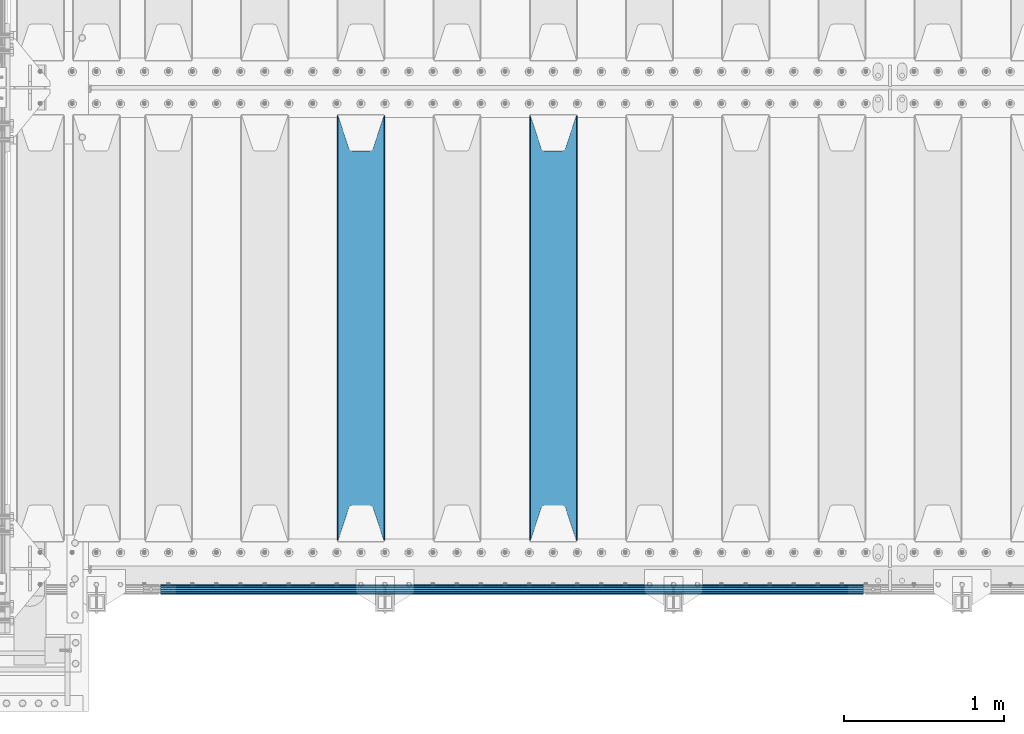
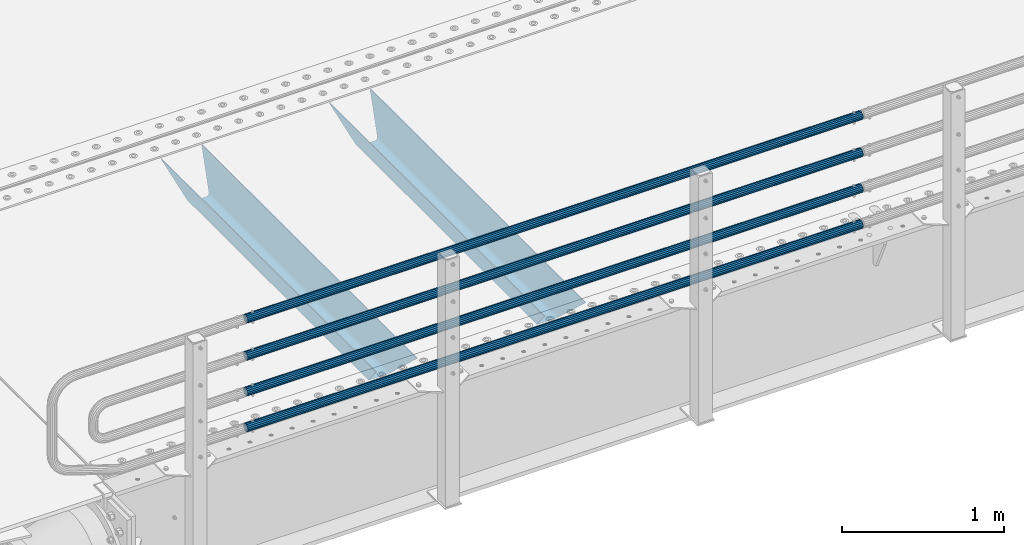
# One storey, part 102 of 257: 6 beams.
"""IFC2X3 building model written with IfcOpenShell, lengths in millimetres."""

from ifc_helpers import new_model, si_unit, frame, origin_with_axes, place, context, subcontext, project, spatial, faceted_brep, material, type_object, element, save


model = new_model("IFC2X3")

# Units and contexts
model_context = context("Model", 3, precision=1e-05, world=origin_with_axes())
body_context = subcontext(model_context, "Body", "Model", "MODEL_VIEW")
ifc_project = project(units=[si_unit("LENGTHUNIT", "METRE", prefix="MILLI"), si_unit("AREAUNIT", "SQUARE_METRE"), si_unit("VOLUMEUNIT", "CUBIC_METRE"), si_unit("MASSUNIT", "GRAM", prefix="KILO"), si_unit("TIMEUNIT", "SECOND"), si_unit("PLANEANGLEUNIT", "RADIAN"), si_unit("SOLIDANGLEUNIT", "STERADIAN"), si_unit("THERMODYNAMICTEMPERATUREUNIT", "DEGREE_CELSIUS"), si_unit("LUMINOUSINTENSITYUNIT", "LUMEN")], contexts=[model_context])

# Site, building, storey
site_placement = place(None, origin_with_axes())
site = spatial("IfcSite", under=ifc_project, at=site_placement, CompositionType="ELEMENT")
building_placement = place(site_placement, origin_with_axes())
building = spatial("IfcBuilding", under=site, at=building_placement, Name="Standard", CompositionType="ELEMENT")
storey_placement = place(building_placement, origin_with_axes())
storey = spatial("IfcBuildingStorey", under=building, at=storey_placement, Name="Undefined", CompositionType="ELEMENT", Elevation=0.0)

# Beams
ifc_material_1 = material(Name="STEEL/S355N")
beam_type_1 = type_object("IfcBeamType", PredefinedType="NOTDEFINED")
beam_1_placement = place(storey_placement, frame((45850.0, 175.0, -115.0), z_axis=(0.0, 0.0, 1.0), x_axis=(0.0, 1.0, 0.0)))
element("IfcBeam", 1, at=beam_1_placement, inside=storey, type_object=beam_type_1, material=ifc_material_1, context=body_context, shape_type="Brep", body=[
    faceted_brep([(0.0, 150.0, 115.0), (0.0, 143.690000000002, 115.0), (2650.00000000297, 143.690000000002, 115.0), (2650.00000000297, 150.0, 115.0), (2650.00000000297, 142.059565218406, 110.0000000031), (2650.00000000297, 148.369565218403, 110.0000000031), (2441.90079219208, -80.1103600731149, -98.0992078077845), (2437.7588105432, -77.5672621345584, -102.241189456673), (2434.06523489746, -74.4080125315522, -105.934765102404), (2430.91086095089, -70.7102721255724, -109.089139048974), (2428.37322971128, -66.5649389910031, -111.626770288588), (2426.51472138055, -62.0739139532889, -113.485278619323), (2425.38102192091, -57.3475956567636, -114.618978078955), (2424.99999999987, -52.5021667386536, -115.0), (2424.99999999987, 52.5021667386536, -115.0), (2425.38102192091, 57.3475956567636, -114.618978078955), (2426.51472138055, 62.0739139532889, -113.485278619323), (2428.37322971128, 66.5649389910031, -111.626770288588), (2430.91086095089, 70.7102721255724, -109.089139048974), (2434.06523489746, 74.4080125315522, -105.934765102404), (2437.7588105432, 77.5672621345584, -102.241189456673), (2441.90079219208, 80.1103600731149, -98.0992078077846), (2446.38936140511, 81.9747917625791, -93.6106385947584), (2448.24948500409, 76.2713538057287, -91.7505149957729), (2444.62967112262, 74.76777986261, -95.3703288772456), (2441.28936334126, 72.7168944282894, -98.710636658607), (2438.31067330438, 70.1691124903809, -101.689326695487), (2435.76682334747, 67.1870637758839, -104.233176652398), (2433.72034654133, 63.8440531834931, -106.279653458539), (2432.22154950041, 60.2222587982324, -107.778450499454), (2431.30727574265, 56.4107117849126, -108.692724257221), (2430.99999999987, 52.5031078186876, -109.0), (2430.99999999987, -52.5031078186876, -109.0), (2431.30727574265, -56.4107117849126, -108.692724257221), (2432.22154950041, -60.2222587982324, -107.778450499454), (2433.72034654133, -63.8440531834931, -106.279653458539), (2435.76682334747, -67.1870637758839, -104.233176652398), (2438.31067330438, -70.1691124903809, -101.689326695487), (2441.28936334126, -72.7168944282894, -98.7106366586071), (2444.62967112262, -74.76777986261, -95.3703288772457), (2448.24948500409, -76.2713538057287, -91.7505149957729), (2650.00000000297, -142.059565218406, 110.0000000031), (2650.00000000297, -148.369565218403, 110.0000000031), (2446.38936140511, -81.9747917625791, -93.6106385947584), (2650.00000000297, -143.690000000002, 115.0), (2650.00000000297, -150.0, 115.0), (0.0, -143.690000000002, 115.0), (0.0, -150.0, 115.0), (0.0, -148.369565218258, 110.000000002662), (203.61063859742, -81.9747917625791, -93.6106385947584), (208.099207810447, -80.1103600731149, -98.0992078077845), (212.241189459335, -77.5672621345584, -102.241189456673), (215.934765105066, -74.4080125315522, -105.934765102404), (219.089139051636, -70.7102721255724, -109.089139048974), (221.626770291251, -66.5649389910031, -111.626770288588), (223.485278621985, -62.0739139532889, -113.485278619323), (224.618978081617, -57.3475956567636, -114.618978078955), (225.000000002662, -52.5021667386536, -115.0), (225.000000002662, 52.5021667386536, -115.0), (224.618978081617, 57.3475956567636, -114.618978078955), (223.485278621985, 62.0739139532889, -113.485278619323), (221.626770291251, 66.5649389910031, -111.626770288588), (219.089139051636, 70.7102721255724, -109.089139048974), (215.934765105066, 74.4080125315522, -105.934765102404), (212.241189459335, 77.5672621345584, -102.241189456673), (208.099207810447, 80.1103600731149, -98.0992078077846), (203.61063859742, 81.9747917625791, -93.6106385947584), (0.0, 148.369565218258, 110.000000002662), (0.0, 142.05956521826, 110.000000002662), (201.750514998435, 76.2713538057287, -91.7505149957729), (205.370328879908, 74.76777986261, -95.3703288772456), (208.710636661269, 72.7168944282894, -98.710636658607), (211.689326698149, 70.1691124903809, -101.689326695487), (214.233176655061, 67.1870637758839, -104.233176652398), (216.279653461201, 63.8440531834931, -106.279653458539), (217.778450502116, 60.2222587982324, -107.778450499454), (218.692724259884, 56.4107117849126, -108.692724257221), (219.000000002662, 52.5031078186876, -109.0), (219.000000002662, -52.5031078186876, -109.0), (218.692724259884, -56.4107117849126, -108.692724257221), (217.778450502116, -60.2222587982324, -107.778450499454), (216.279653461201, -63.8440531834931, -106.279653458539), (214.233176655061, -67.1870637758839, -104.233176652398), (211.689326698149, -70.1691124903809, -101.689326695487), (208.710636661269, -72.7168944282894, -98.7106366586071), (205.370328879908, -74.76777986261, -95.3703288772457), (201.750514998435, -76.2713538057287, -91.7505149957729), (0.0, -142.05956521826, 110.000000002662)], [[[0, 1, 2, 3]], [[3, 2, 4, 5]], [[6, 7, 8, 9, 10, 11, 12, 13, 14, 15, 16, 17, 18, 19, 20, 21, 22, 5, 4, 23, 24, 25, 26, 27, 28, 29, 30, 31, 32, 33, 34, 35, 36, 37, 38, 39, 40, 41, 42, 43]], [[44, 45, 42, 41]], [[46, 47, 45, 44]], [[43, 42, 45, 47, 48, 49]], [[6, 43, 49, 50]], [[7, 6, 50, 51]], [[8, 7, 51, 52]], [[9, 8, 52, 53]], [[10, 9, 53, 54]], [[11, 10, 54, 55]], [[12, 11, 55, 56]], [[13, 12, 56, 57]], [[14, 13, 57, 58]], [[15, 14, 58, 59]], [[16, 15, 59, 60]], [[17, 16, 60, 61]], [[18, 17, 61, 62]], [[19, 18, 62, 63]], [[20, 19, 63, 64]], [[21, 20, 64, 65]], [[22, 21, 65, 66]], [[0, 3, 5, 22, 66, 67]], [[1, 0, 67, 68]], [[23, 4, 2, 1, 68, 69]], [[24, 23, 69, 70]], [[25, 24, 70, 71]], [[26, 25, 71, 72]], [[27, 26, 72, 73]], [[28, 27, 73, 74]], [[29, 28, 74, 75]], [[30, 29, 75, 76]], [[31, 30, 76, 77]], [[32, 31, 77, 78]], [[33, 32, 78, 79]], [[34, 33, 79, 80]], [[35, 34, 80, 81]], [[36, 35, 81, 82]], [[37, 36, 82, 83]], [[38, 37, 83, 84]], [[39, 38, 84, 85]], [[40, 39, 85, 86]], [[46, 44, 41, 40, 86, 87]], [[47, 46, 87, 48]], [[86, 85, 84, 83, 82, 81, 80, 79, 78, 77, 76, 75, 74, 73, 72, 71, 70, 69, 68, 67, 66, 65, 64, 63, 62, 61, 60, 59, 58, 57, 56, 55, 54, 53, 52, 51, 50, 49, 48, 87]]]),
])
beam_2_placement = place(storey_placement, frame((44650.0, 175.0, -115.0), z_axis=(0.0, 0.0, 1.0), x_axis=(0.0, 1.0, 0.0)))
element("IfcBeam", 2, at=beam_2_placement, inside=storey, type_object=beam_type_1, material=ifc_material_1, context=body_context, shape_type="Brep", body=[
    faceted_brep([(0.0, 150.0, 115.0), (0.0, 143.690000000002, 115.0), (2650.00000000297, 143.690000000002, 115.0), (2650.00000000297, 150.0, 115.0), (2650.00000000297, 142.059565218406, 110.0000000031), (2650.00000000297, 148.369565218403, 110.0000000031), (2441.90079219208, -80.1103600731149, -98.0992078077845), (2437.7588105432, -77.5672621345584, -102.241189456673), (2434.06523489746, -74.4080125315522, -105.934765102404), (2430.91086095089, -70.7102721255724, -109.089139048974), (2428.37322971128, -66.5649389910031, -111.626770288588), (2426.51472138055, -62.0739139532889, -113.485278619323), (2425.38102192091, -57.3475956567636, -114.618978078955), (2424.99999999987, -52.5021667386536, -115.0), (2424.99999999987, 52.5021667386536, -115.0), (2425.38102192091, 57.3475956567636, -114.618978078955), (2426.51472138055, 62.0739139532889, -113.485278619323), (2428.37322971128, 66.5649389910031, -111.626770288588), (2430.91086095089, 70.7102721255724, -109.089139048974), (2434.06523489746, 74.4080125315522, -105.934765102404), (2437.7588105432, 77.5672621345584, -102.241189456673), (2441.90079219208, 80.1103600731149, -98.0992078077846), (2446.38936140511, 81.9747917625791, -93.6106385947584), (2448.24948500409, 76.2713538057287, -91.7505149957729), (2444.62967112262, 74.76777986261, -95.3703288772456), (2441.28936334126, 72.7168944282894, -98.710636658607), (2438.31067330438, 70.1691124903809, -101.689326695487), (2435.76682334747, 67.1870637758839, -104.233176652398), (2433.72034654133, 63.8440531834931, -106.279653458539), (2432.22154950041, 60.2222587982324, -107.778450499454), (2431.30727574265, 56.4107117849126, -108.692724257221), (2430.99999999987, 52.5031078186876, -109.0), (2430.99999999987, -52.5031078186876, -109.0), (2431.30727574265, -56.4107117849126, -108.692724257221), (2432.22154950041, -60.2222587982324, -107.778450499454), (2433.72034654133, -63.8440531834931, -106.279653458539), (2435.76682334747, -67.1870637758839, -104.233176652398), (2438.31067330438, -70.1691124903809, -101.689326695487), (2441.28936334126, -72.7168944282894, -98.7106366586071), (2444.62967112262, -74.76777986261, -95.3703288772457), (2448.24948500409, -76.2713538057287, -91.7505149957729), (2650.00000000297, -142.059565218406, 110.0000000031), (2650.00000000297, -148.369565218403, 110.0000000031), (2446.38936140511, -81.9747917625791, -93.6106385947584), (2650.00000000297, -143.690000000002, 115.0), (2650.00000000297, -150.0, 115.0), (0.0, -143.690000000002, 115.0), (0.0, -150.0, 115.0), (0.0, -148.369565218258, 110.000000002662), (203.61063859742, -81.9747917625791, -93.6106385947584), (208.099207810447, -80.1103600731149, -98.0992078077845), (212.241189459335, -77.5672621345584, -102.241189456673), (215.934765105066, -74.4080125315522, -105.934765102404), (219.089139051636, -70.7102721255724, -109.089139048974), (221.626770291251, -66.5649389910031, -111.626770288588), (223.485278621985, -62.0739139532889, -113.485278619323), (224.618978081617, -57.3475956567636, -114.618978078955), (225.000000002662, -52.5021667386536, -115.0), (225.000000002662, 52.5021667386536, -115.0), (224.618978081617, 57.3475956567636, -114.618978078955), (223.485278621985, 62.0739139532889, -113.485278619323), (221.626770291251, 66.5649389910031, -111.626770288588), (219.089139051636, 70.7102721255724, -109.089139048974), (215.934765105066, 74.4080125315522, -105.934765102404), (212.241189459335, 77.5672621345584, -102.241189456673), (208.099207810447, 80.1103600731149, -98.0992078077846), (203.61063859742, 81.9747917625791, -93.6106385947584), (0.0, 148.369565218258, 110.000000002662), (0.0, 142.05956521826, 110.000000002662), (201.750514998435, 76.2713538057287, -91.7505149957729), (205.370328879908, 74.76777986261, -95.3703288772456), (208.710636661269, 72.7168944282894, -98.710636658607), (211.689326698149, 70.1691124903809, -101.689326695487), (214.233176655061, 67.1870637758839, -104.233176652398), (216.279653461201, 63.8440531834931, -106.279653458539), (217.778450502116, 60.2222587982324, -107.778450499454), (218.692724259884, 56.4107117849126, -108.692724257221), (219.000000002662, 52.5031078186876, -109.0), (219.000000002662, -52.5031078186876, -109.0), (218.692724259884, -56.4107117849126, -108.692724257221), (217.778450502116, -60.2222587982324, -107.778450499454), (216.279653461201, -63.8440531834931, -106.279653458539), (214.233176655061, -67.1870637758839, -104.233176652398), (211.689326698149, -70.1691124903809, -101.689326695487), (208.710636661269, -72.7168944282894, -98.7106366586071), (205.370328879908, -74.76777986261, -95.3703288772457), (201.750514998435, -76.2713538057287, -91.7505149957729), (0.0, -142.05956521826, 110.000000002662)], [[[0, 1, 2, 3]], [[3, 2, 4, 5]], [[6, 7, 8, 9, 10, 11, 12, 13, 14, 15, 16, 17, 18, 19, 20, 21, 22, 5, 4, 23, 24, 25, 26, 27, 28, 29, 30, 31, 32, 33, 34, 35, 36, 37, 38, 39, 40, 41, 42, 43]], [[44, 45, 42, 41]], [[46, 47, 45, 44]], [[43, 42, 45, 47, 48, 49]], [[6, 43, 49, 50]], [[7, 6, 50, 51]], [[8, 7, 51, 52]], [[9, 8, 52, 53]], [[10, 9, 53, 54]], [[11, 10, 54, 55]], [[12, 11, 55, 56]], [[13, 12, 56, 57]], [[14, 13, 57, 58]], [[15, 14, 58, 59]], [[16, 15, 59, 60]], [[17, 16, 60, 61]], [[18, 17, 61, 62]], [[19, 18, 62, 63]], [[20, 19, 63, 64]], [[21, 20, 64, 65]], [[22, 21, 65, 66]], [[0, 3, 5, 22, 66, 67]], [[1, 0, 67, 68]], [[23, 4, 2, 1, 68, 69]], [[24, 23, 69, 70]], [[25, 24, 70, 71]], [[26, 25, 71, 72]], [[27, 26, 72, 73]], [[28, 27, 73, 74]], [[29, 28, 74, 75]], [[30, 29, 75, 76]], [[31, 30, 76, 77]], [[32, 31, 77, 78]], [[33, 32, 78, 79]], [[34, 33, 79, 80]], [[35, 34, 80, 81]], [[36, 35, 81, 82]], [[37, 36, 82, 83]], [[38, 37, 83, 84]], [[39, 38, 84, 85]], [[40, 39, 85, 86]], [[46, 44, 41, 40, 86, 87]], [[47, 46, 87, 48]], [[86, 85, 84, 83, 82, 81, 80, 79, 78, 77, 76, 75, 74, 73, 72, 71, 70, 69, 68, 67, 66, 65, 64, 63, 62, 61, 60, 59, 58, 57, 56, 55, 54, 53, 52, 51, 50, 49, 48, 87]]]),
])
ifc_material_2 = material()
beam_type_2 = type_object("IfcBeamType", PredefinedType="NOTDEFINED")
beam_3_placement = place(storey_placement, frame((47783.9999999999, -129.849999999907, 149.849999999725), z_axis=(0.0, 0.0, -1.0), x_axis=(-1.0, 0.0, 0.0)))
element("IfcBeam", 3, at=beam_3_placement, inside=storey, type_object=beam_type_2, material=ifc_material_2, context=body_context, shape_type="Brep", body=[
    faceted_brep([(0.0, -26.5499999999993, 0.0), (0.0, -24.5290015881747, 10.1602451292931), (4384.00249699992, -24.5290015881747, 10.1602451292931), (4384.00249699992, -26.5499999999993, 0.0), (0.0, -18.7736850405036, 18.7736850405028), (4384.00249699992, -18.7736850405036, 18.7736850405028), (0.0, -10.1602451292929, 24.5290015881747), (4384.00249699992, -10.1602451292929, 24.5290015881747), (0.0, 0.0, 26.55), (4384.00249699992, 0.0, 26.55), (0.0, 10.1602451292929, 24.5290015881747), (4384.00249699992, 10.1602451292929, 24.5290015881747), (0.0, 18.7736850405036, 18.7736850405028), (4384.00249699992, 18.7736850405036, 18.7736850405028), (0.0, 24.5290015881747, 10.1602451292931), (4384.00249699992, 24.5290015881747, 10.1602451292931), (0.0, 26.5499999999993, 0.0), (4384.00249699992, 26.5499999999993, 0.0), (0.0, 24.5290015881747, -10.1602451292931), (4384.00249699992, 24.5290015881747, -10.1602451292931), (0.0, 18.7736850405036, -18.7736850405028), (4384.00249699992, 18.7736850405036, -18.7736850405028), (0.0, 10.1602451292929, -24.5290015881747), (4384.00249699992, 10.1602451292929, -24.5290015881747), (0.0, 0.0, -26.55), (4384.00249699992, 0.0, -26.55), (0.0, -10.1602451292929, -24.5290015881747), (4384.00249699992, -10.1602451292929, -24.5290015881747), (0.0, -18.7736850405036, -18.7736850405028), (4384.00249699992, -18.7736850405036, -18.7736850405028), (0.0, -24.5290015881747, -10.1602451292931), (4384.00249699992, -24.5290015881747, -10.1602451292931), (0.0, -30.1499999999996, 0.0), (0.0, -27.8549679052157, -11.5379054858058), (4384.00249699992, -27.8549679052157, -11.5379054858075), (4384.00249699992, -30.1499999999996, 0.0), (0.0, -21.3192694527752, -21.3192694527752), (4384.00249699992, -21.3192694527752, -21.3192694527744), (0.0, -11.5379054858076, -27.8549679052157), (4384.00249699992, -11.5379054858076, -27.8549679052153), (0.0, 0.0, -30.1500000000015), (4384.00249699992, 0.0, -30.15), (0.0, 11.5379054858076, -27.8549679052157), (4384.00249699992, 11.5379054858076, -27.8549679052153), (0.0, 21.3192694527752, -21.3192694527752), (4384.00249699992, 21.3192694527752, -21.3192694527744), (0.0, 27.8549679052157, -11.5379054858058), (4384.00249699992, 27.8549679052157, -11.5379054858074), (0.0, 30.1499999999996, 0.0), (4384.00249699992, 30.1499999999996, 0.0), (0.0, 27.8549679052157, 11.5379054858058), (4384.00249699992, 27.8549679052157, 11.5379054858075), (0.0, 21.3192694527752, 21.3192694527752), (4384.00249699992, 21.3192694527752, 21.3192694527744), (0.0, 11.5379054858076, 27.8549679052157), (4384.00249699992, 11.5379054858076, 27.8549679052153), (0.0, 0.0, 30.1500000000015), (4384.00249699992, 0.0, 30.15), (0.0, -11.5379054858076, 27.8549679052157), (4384.00249699992, -11.5379054858076, 27.8549679052153), (0.0, -21.3192694527752, 21.3192694527752), (4384.00249699992, -21.3192694527752, 21.3192694527744), (0.0, -27.8549679052157, 11.5379054858058), (4384.00249699992, -27.8549679052157, 11.5379054858075)], [[[0, 1, 2, 3]], [[1, 4, 5, 2]], [[4, 6, 7, 5]], [[6, 8, 9, 7]], [[8, 10, 11, 9]], [[10, 12, 13, 11]], [[12, 14, 15, 13]], [[14, 16, 17, 15]], [[16, 18, 19, 17]], [[18, 20, 21, 19]], [[20, 22, 23, 21]], [[22, 24, 25, 23]], [[24, 26, 27, 25]], [[26, 28, 29, 27]], [[28, 30, 31, 29]], [[30, 0, 3, 31]], [[32, 33, 34, 35]], [[33, 36, 37, 34]], [[36, 38, 39, 37]], [[38, 40, 41, 39]], [[40, 42, 43, 41]], [[42, 44, 45, 43]], [[44, 46, 47, 45]], [[46, 48, 49, 47]], [[48, 50, 51, 49]], [[50, 52, 53, 51]], [[52, 54, 55, 53]], [[54, 56, 57, 55]], [[56, 58, 59, 57]], [[58, 60, 61, 59]], [[60, 62, 63, 61]], [[62, 32, 35, 63]], [[37, 39, 41, 43, 45, 47, 49, 51, 53, 55, 57, 59, 61, 63, 35, 34], [5, 7, 9, 11, 13, 15, 17, 19, 21, 23, 25, 27, 29, 31, 3, 2]], [[62, 60, 58, 56, 54, 52, 50, 48, 46, 44, 42, 40, 38, 36, 33, 32], [30, 28, 26, 24, 22, 20, 18, 16, 14, 12, 10, 8, 6, 4, 1, 0]]]),
])
beam_4_placement = place(storey_placement, frame((47783.9999999999, -129.849999999907, 420.149999999728), z_axis=(0.0, 0.0, -1.0), x_axis=(-1.0, 0.0, 0.0)))
element("IfcBeam", 4, at=beam_4_placement, inside=storey, type_object=beam_type_2, material=ifc_material_2, context=body_context, shape_type="Brep", body=[
    faceted_brep([(0.0, -26.5499999999993, 0.0), (0.0, -24.5290015881747, 10.1602451292931), (4384.00249699992, -24.5290015881747, 10.1602451292931), (4384.00249699992, -26.5499999999993, 0.0), (0.0, -18.7736850405036, 18.7736850405028), (4384.00249699992, -18.7736850405036, 18.7736850405028), (0.0, -10.1602451292929, 24.5290015881747), (4384.00249699992, -10.1602451292929, 24.5290015881747), (0.0, 0.0, 26.55), (4384.00249699992, 0.0, 26.55), (0.0, 10.1602451292929, 24.5290015881747), (4384.00249699992, 10.1602451292929, 24.5290015881747), (0.0, 18.7736850405036, 18.7736850405028), (4384.00249699992, 18.7736850405036, 18.7736850405028), (0.0, 24.5290015881747, 10.1602451292931), (4384.00249699992, 24.5290015881747, 10.1602451292931), (0.0, 26.5499999999993, 0.0), (4384.00249699992, 26.5499999999993, 0.0), (0.0, 24.5290015881747, -10.1602451292931), (4384.00249699992, 24.5290015881747, -10.1602451292931), (0.0, 18.7736850405036, -18.7736850405028), (4384.00249699992, 18.7736850405036, -18.7736850405028), (0.0, 10.1602451292929, -24.5290015881747), (4384.00249699992, 10.1602451292929, -24.5290015881747), (0.0, 0.0, -26.55), (4384.00249699992, 0.0, -26.55), (0.0, -10.1602451292929, -24.5290015881747), (4384.00249699992, -10.1602451292929, -24.5290015881747), (0.0, -18.7736850405036, -18.7736850405028), (4384.00249699992, -18.7736850405036, -18.7736850405028), (0.0, -24.5290015881747, -10.1602451292931), (4384.00249699992, -24.5290015881747, -10.1602451292931), (0.0, -30.1499999999996, 0.0), (0.0, -27.8549679052157, -11.5379054858058), (4384.00249699992, -27.8549679052157, -11.5379054858075), (4384.00249699992, -30.1499999999996, 0.0), (0.0, -21.3192694527752, -21.3192694527752), (4384.00249699992, -21.3192694527752, -21.3192694527744), (0.0, -11.5379054858076, -27.8549679052157), (4384.00249699992, -11.5379054858076, -27.8549679052153), (0.0, 0.0, -30.1500000000015), (4384.00249699992, 0.0, -30.15), (0.0, 11.5379054858076, -27.8549679052157), (4384.00249699992, 11.5379054858076, -27.8549679052153), (0.0, 21.3192694527752, -21.3192694527752), (4384.00249699992, 21.3192694527752, -21.3192694527744), (0.0, 27.8549679052157, -11.5379054858058), (4384.00249699992, 27.8549679052157, -11.5379054858074), (0.0, 30.1499999999996, 0.0), (4384.00249699992, 30.1499999999996, 0.0), (0.0, 27.8549679052157, 11.5379054858058), (4384.00249699992, 27.8549679052157, 11.5379054858075), (0.0, 21.3192694527752, 21.3192694527752), (4384.00249699992, 21.3192694527752, 21.3192694527744), (0.0, 11.5379054858076, 27.8549679052157), (4384.00249699992, 11.5379054858076, 27.8549679052153), (0.0, 0.0, 30.1500000000015), (4384.00249699992, 0.0, 30.15), (0.0, -11.5379054858076, 27.8549679052157), (4384.00249699992, -11.5379054858076, 27.8549679052153), (0.0, -21.3192694527752, 21.3192694527752), (4384.00249699992, -21.3192694527752, 21.3192694527744), (0.0, -27.8549679052157, 11.5379054858058), (4384.00249699992, -27.8549679052157, 11.5379054858075)], [[[0, 1, 2, 3]], [[1, 4, 5, 2]], [[4, 6, 7, 5]], [[6, 8, 9, 7]], [[8, 10, 11, 9]], [[10, 12, 13, 11]], [[12, 14, 15, 13]], [[14, 16, 17, 15]], [[16, 18, 19, 17]], [[18, 20, 21, 19]], [[20, 22, 23, 21]], [[22, 24, 25, 23]], [[24, 26, 27, 25]], [[26, 28, 29, 27]], [[28, 30, 31, 29]], [[30, 0, 3, 31]], [[32, 33, 34, 35]], [[33, 36, 37, 34]], [[36, 38, 39, 37]], [[38, 40, 41, 39]], [[40, 42, 43, 41]], [[42, 44, 45, 43]], [[44, 46, 47, 45]], [[46, 48, 49, 47]], [[48, 50, 51, 49]], [[50, 52, 53, 51]], [[52, 54, 55, 53]], [[54, 56, 57, 55]], [[56, 58, 59, 57]], [[58, 60, 61, 59]], [[60, 62, 63, 61]], [[62, 32, 35, 63]], [[37, 39, 41, 43, 45, 47, 49, 51, 53, 55, 57, 59, 61, 63, 35, 34], [5, 7, 9, 11, 13, 15, 17, 19, 21, 23, 25, 27, 29, 31, 3, 2]], [[62, 60, 58, 56, 54, 52, 50, 48, 46, 44, 42, 40, 38, 36, 33, 32], [30, 28, 26, 24, 22, 20, 18, 16, 14, 12, 10, 8, 6, 4, 1, 0]]]),
])
beam_5_placement = place(storey_placement, frame((47783.9999999999, -129.849999999907, 969.849999999725), z_axis=(0.0, 0.0, -1.0), x_axis=(-1.0, 0.0, 0.0)))
element("IfcBeam", 5, at=beam_5_placement, inside=storey, type_object=beam_type_2, material=ifc_material_2, context=body_context, shape_type="Brep", body=[
    faceted_brep([(0.0, -26.5499999999993, 0.0), (0.0, -24.5290015881747, 10.1602451292931), (4384.00249699992, -24.5290015881747, 10.1602451292931), (4384.00249699992, -26.5499999999993, 0.0), (0.0, -18.7736850405036, 18.7736850405028), (4384.00249699992, -18.7736850405036, 18.7736850405028), (0.0, -10.1602451292929, 24.5290015881747), (4384.00249699992, -10.1602451292929, 24.5290015881747), (0.0, 0.0, 26.55), (4384.00249699992, 0.0, 26.55), (0.0, 10.1602451292929, 24.5290015881747), (4384.00249699992, 10.1602451292929, 24.5290015881747), (0.0, 18.7736850405036, 18.7736850405028), (4384.00249699992, 18.7736850405036, 18.7736850405028), (0.0, 24.5290015881747, 10.1602451292931), (4384.00249699992, 24.5290015881747, 10.1602451292931), (0.0, 26.5499999999993, 0.0), (4384.00249699992, 26.5499999999993, 0.0), (0.0, 24.5290015881747, -10.1602451292931), (4384.00249699992, 24.5290015881747, -10.1602451292931), (0.0, 18.7736850405036, -18.7736850405028), (4384.00249699992, 18.7736850405036, -18.7736850405028), (0.0, 10.1602451292929, -24.5290015881747), (4384.00249699992, 10.1602451292929, -24.5290015881747), (0.0, 0.0, -26.55), (4384.00249699992, 0.0, -26.55), (0.0, -10.1602451292929, -24.5290015881747), (4384.00249699992, -10.1602451292929, -24.5290015881747), (0.0, -18.7736850405036, -18.7736850405028), (4384.00249699992, -18.7736850405036, -18.7736850405028), (0.0, -24.5290015881747, -10.1602451292931), (4384.00249699992, -24.5290015881747, -10.1602451292931), (0.0, -30.1499999999996, 0.0), (0.0, -27.8549679052157, -11.5379054858058), (4384.00249699992, -27.8549679052157, -11.5379054858075), (4384.00249699992, -30.1499999999996, 0.0), (0.0, -21.3192694527752, -21.3192694527752), (4384.00249699992, -21.3192694527752, -21.3192694527744), (0.0, -11.5379054858076, -27.8549679052157), (4384.00249699992, -11.5379054858076, -27.8549679052153), (0.0, 0.0, -30.1500000000015), (4384.00249699992, 0.0, -30.15), (0.0, 11.5379054858076, -27.8549679052157), (4384.00249699992, 11.5379054858076, -27.8549679052153), (0.0, 21.3192694527752, -21.3192694527752), (4384.00249699992, 21.3192694527752, -21.3192694527744), (0.0, 27.8549679052157, -11.5379054858058), (4384.00249699992, 27.8549679052157, -11.5379054858074), (0.0, 30.1499999999996, 0.0), (4384.00249699992, 30.1499999999996, 0.0), (0.0, 27.8549679052157, 11.5379054858058), (4384.00249699992, 27.8549679052157, 11.5379054858075), (0.0, 21.3192694527752, 21.3192694527752), (4384.00249699992, 21.3192694527752, 21.3192694527744), (0.0, 11.5379054858076, 27.8549679052157), (4384.00249699992, 11.5379054858076, 27.8549679052153), (0.0, 0.0, 30.1500000000015), (4384.00249699992, 0.0, 30.15), (0.0, -11.5379054858076, 27.8549679052157), (4384.00249699992, -11.5379054858076, 27.8549679052153), (0.0, -21.3192694527752, 21.3192694527752), (4384.00249699992, -21.3192694527752, 21.3192694527744), (0.0, -27.8549679052157, 11.5379054858058), (4384.00249699992, -27.8549679052157, 11.5379054858075)], [[[0, 1, 2, 3]], [[1, 4, 5, 2]], [[4, 6, 7, 5]], [[6, 8, 9, 7]], [[8, 10, 11, 9]], [[10, 12, 13, 11]], [[12, 14, 15, 13]], [[14, 16, 17, 15]], [[16, 18, 19, 17]], [[18, 20, 21, 19]], [[20, 22, 23, 21]], [[22, 24, 25, 23]], [[24, 26, 27, 25]], [[26, 28, 29, 27]], [[28, 30, 31, 29]], [[30, 0, 3, 31]], [[32, 33, 34, 35]], [[33, 36, 37, 34]], [[36, 38, 39, 37]], [[38, 40, 41, 39]], [[40, 42, 43, 41]], [[42, 44, 45, 43]], [[44, 46, 47, 45]], [[46, 48, 49, 47]], [[48, 50, 51, 49]], [[50, 52, 53, 51]], [[52, 54, 55, 53]], [[54, 56, 57, 55]], [[56, 58, 59, 57]], [[58, 60, 61, 59]], [[60, 62, 63, 61]], [[62, 32, 35, 63]], [[37, 39, 41, 43, 45, 47, 49, 51, 53, 55, 57, 59, 61, 63, 35, 34], [5, 7, 9, 11, 13, 15, 17, 19, 21, 23, 25, 27, 29, 31, 3, 2]], [[62, 60, 58, 56, 54, 52, 50, 48, 46, 44, 42, 40, 38, 36, 33, 32], [30, 28, 26, 24, 22, 20, 18, 16, 14, 12, 10, 8, 6, 4, 1, 0]]]),
])
beam_6_placement = place(storey_placement, frame((47783.9999999999, -129.849999999907, 689.849999999725), z_axis=(0.0, 0.0, -1.0), x_axis=(-1.0, 0.0, 0.0)))
element("IfcBeam", 6, at=beam_6_placement, inside=storey, type_object=beam_type_2, material=ifc_material_2, context=body_context, shape_type="Brep", body=[
    faceted_brep([(0.0, -26.5499999999993, 0.0), (0.0, -24.5290015881747, 10.1602451292931), (4384.00249699992, -24.5290015881747, 10.1602451292931), (4384.00249699992, -26.5499999999993, 0.0), (0.0, -18.7736850405036, 18.7736850405028), (4384.00249699992, -18.7736850405036, 18.7736850405028), (0.0, -10.1602451292929, 24.5290015881747), (4384.00249699992, -10.1602451292929, 24.5290015881747), (0.0, 0.0, 26.55), (4384.00249699992, 0.0, 26.55), (0.0, 10.1602451292929, 24.5290015881747), (4384.00249699992, 10.1602451292929, 24.5290015881747), (0.0, 18.7736850405036, 18.7736850405028), (4384.00249699992, 18.7736850405036, 18.7736850405028), (0.0, 24.5290015881747, 10.1602451292931), (4384.00249699992, 24.5290015881747, 10.1602451292931), (0.0, 26.5499999999993, 0.0), (4384.00249699992, 26.5499999999993, 0.0), (0.0, 24.5290015881747, -10.1602451292931), (4384.00249699992, 24.5290015881747, -10.1602451292931), (0.0, 18.7736850405036, -18.7736850405028), (4384.00249699992, 18.7736850405036, -18.7736850405028), (0.0, 10.1602451292929, -24.5290015881747), (4384.00249699992, 10.1602451292929, -24.5290015881747), (0.0, 0.0, -26.55), (4384.00249699992, 0.0, -26.55), (0.0, -10.1602451292929, -24.5290015881747), (4384.00249699992, -10.1602451292929, -24.5290015881747), (0.0, -18.7736850405036, -18.7736850405028), (4384.00249699992, -18.7736850405036, -18.7736850405028), (0.0, -24.5290015881747, -10.1602451292931), (4384.00249699992, -24.5290015881747, -10.1602451292931), (0.0, -30.1499999999996, 0.0), (0.0, -27.8549679052157, -11.5379054858058), (4384.00249699992, -27.8549679052157, -11.5379054858075), (4384.00249699992, -30.1499999999996, 0.0), (0.0, -21.3192694527752, -21.3192694527752), (4384.00249699992, -21.3192694527752, -21.3192694527744), (0.0, -11.5379054858076, -27.8549679052157), (4384.00249699992, -11.5379054858076, -27.8549679052153), (0.0, 0.0, -30.1500000000015), (4384.00249699992, 0.0, -30.15), (0.0, 11.5379054858076, -27.8549679052157), (4384.00249699992, 11.5379054858076, -27.8549679052153), (0.0, 21.3192694527752, -21.3192694527752), (4384.00249699992, 21.3192694527752, -21.3192694527744), (0.0, 27.8549679052157, -11.5379054858058), (4384.00249699992, 27.8549679052157, -11.5379054858074), (0.0, 30.1499999999996, 0.0), (4384.00249699992, 30.1499999999996, 0.0), (0.0, 27.8549679052157, 11.5379054858058), (4384.00249699992, 27.8549679052157, 11.5379054858075), (0.0, 21.3192694527752, 21.3192694527752), (4384.00249699992, 21.3192694527752, 21.3192694527744), (0.0, 11.5379054858076, 27.8549679052157), (4384.00249699992, 11.5379054858076, 27.8549679052153), (0.0, 0.0, 30.1500000000015), (4384.00249699992, 0.0, 30.15), (0.0, -11.5379054858076, 27.8549679052157), (4384.00249699992, -11.5379054858076, 27.8549679052153), (0.0, -21.3192694527752, 21.3192694527752), (4384.00249699992, -21.3192694527752, 21.3192694527744), (0.0, -27.8549679052157, 11.5379054858058), (4384.00249699992, -27.8549679052157, 11.5379054858075)], [[[0, 1, 2, 3]], [[1, 4, 5, 2]], [[4, 6, 7, 5]], [[6, 8, 9, 7]], [[8, 10, 11, 9]], [[10, 12, 13, 11]], [[12, 14, 15, 13]], [[14, 16, 17, 15]], [[16, 18, 19, 17]], [[18, 20, 21, 19]], [[20, 22, 23, 21]], [[22, 24, 25, 23]], [[24, 26, 27, 25]], [[26, 28, 29, 27]], [[28, 30, 31, 29]], [[30, 0, 3, 31]], [[32, 33, 34, 35]], [[33, 36, 37, 34]], [[36, 38, 39, 37]], [[38, 40, 41, 39]], [[40, 42, 43, 41]], [[42, 44, 45, 43]], [[44, 46, 47, 45]], [[46, 48, 49, 47]], [[48, 50, 51, 49]], [[50, 52, 53, 51]], [[52, 54, 55, 53]], [[54, 56, 57, 55]], [[56, 58, 59, 57]], [[58, 60, 61, 59]], [[60, 62, 63, 61]], [[62, 32, 35, 63]], [[37, 39, 41, 43, 45, 47, 49, 51, 53, 55, 57, 59, 61, 63, 35, 34], [5, 7, 9, 11, 13, 15, 17, 19, 21, 23, 25, 27, 29, 31, 3, 2]], [[62, 60, 58, 56, 54, 52, 50, 48, 46, 44, 42, 40, 38, 36, 33, 32], [30, 28, 26, 24, 22, 20, 18, 16, 14, 12, 10, 8, 6, 4, 1, 0]]]),
])

save(model, "model.ifc")
